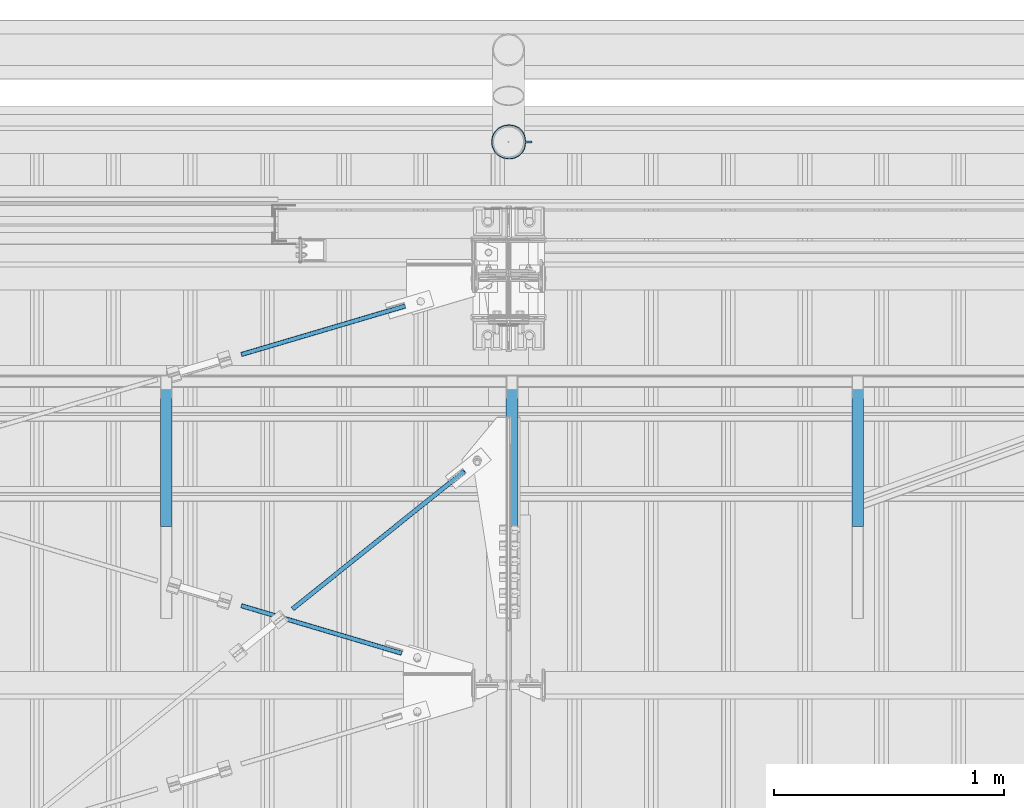
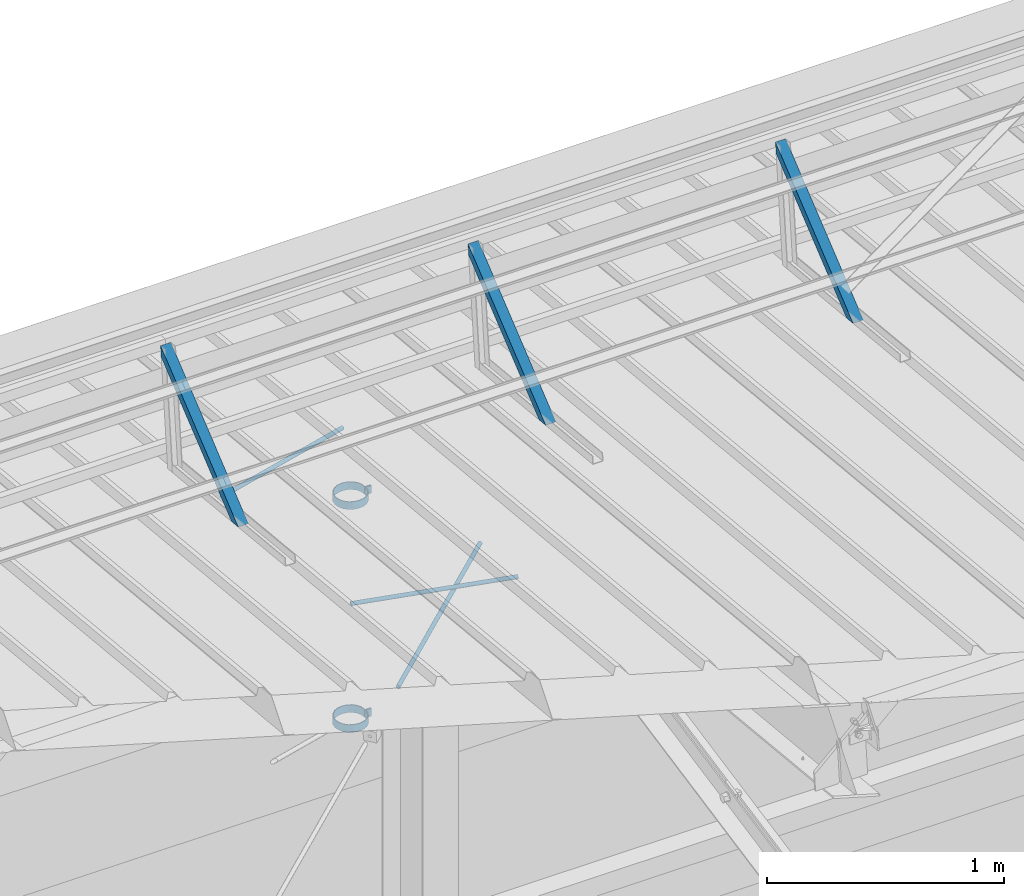
# One storey, part 305 of 709: 5 beams, 3 members, 3 openings, 8 elements without a shape of their own.
"""IFC4 building model written with IfcOpenShell, lengths in millimetres."""

from ifc_helpers import new_model, si_unit, direction, frame, origin_with_axes, place, context, subcontext, project, spatial, line, indexed_curve, outline, extrude, polygons, material, element, aggregate, save


model = new_model("IFC4")

# Units and contexts
model_context = context("Model", 3, precision=0.2, world=origin_with_axes(), true_north=direction((0.0, 1.0)))
body_context = subcontext(model_context, "Body", "Model", "MODEL_VIEW")
reference_context = subcontext(model_context, "Reference", "Model", "MODEL_VIEW")
ifc_project = project(units=[si_unit("LENGTHUNIT", "METRE", prefix="MILLI"), si_unit("AREAUNIT", "SQUARE_METRE"), si_unit("VOLUMEUNIT", "CUBIC_METRE"), si_unit("MASSUNIT", "GRAM", prefix="KILO"), si_unit("TIMEUNIT", "SECOND"), si_unit("PLANEANGLEUNIT", "RADIAN"), si_unit("SOLIDANGLEUNIT", "STERADIAN"), si_unit("THERMODYNAMICTEMPERATUREUNIT", "DEGREE_CELSIUS"), si_unit("LUMINOUSINTENSITYUNIT", "LUMEN")], contexts=[model_context])

# Site, building, storey
site_placement = place(None, origin_with_axes())
site = spatial("IfcSite", under=ifc_project, at=site_placement, CompositionType="ELEMENT")
building_placement = place(site_placement, origin_with_axes())
building = spatial("IfcBuilding", under=site, at=building_placement, Name="Undefined", CompositionType="ELEMENT")
storey_placement = place(building_placement, origin_with_axes())
storey = spatial("IfcBuildingStorey", under=building, at=storey_placement, Name="Undefined", CompositionType="ELEMENT", Elevation=0.0)

# Assembly, beam, voiding feature
assembly_1_placement = place(storey_placement, frame((8916.07962, 20275.59044, 6772.92001), z_axis=(0.625451877, -0.7802627439, 1e-10), x_axis=(0.7742288439, 0.6206151549, 0.124123031)))
assembly_1 = element("IfcElementAssembly", 1, at=assembly_1_placement, inside=storey)
ifc_material_1 = material(Name="C355-5", Category="STEEL")
beam_1_placement = place(assembly_1_placement, origin_with_axes())
beam_1 = element("IfcBeam", 2, at=beam_1_placement, material=ifc_material_1, ObjectType="481", context=body_context, shape_type="Tessellation", body=[
    polygons([(1153.34134, -5.0, 8.66025), (1153.34134, -7.07107, 7.07107), (1153.34134, -8.66025, 5.0), (1153.34134, -9.65926, 2.58819), (1153.34134, -10.0, 0.0), (1153.34134, -9.65926, -2.58819), (1153.34134, -8.66025, -5.0), (1153.34134, -7.07107, -7.07107), (1153.34134, -5.0, -8.66025), (1153.34134, -2.58819, -9.65926), (1153.34134, 0.0, -10.0), (1153.34134, 2.58819, -9.65926), (1153.34134, 5.0, -8.66025), (1153.34134, 7.07107, -7.07107), (1153.34134, 8.66025, -5.0), (1153.34134, 9.65926, -2.58819), (1153.34134, 10.0, 0.0), (1153.34134, 9.65926, 2.58819), (1153.34134, 8.66025, 5.0), (1153.34134, 7.07107, 7.07107), (1153.34134, 5.0, 8.66025), (1153.34134, 2.58819, 9.65926), (1153.34134, 0.0, 10.0), (1153.34134, -2.58819, 9.65926), (190.0, 10.0, 0.0), (190.0, 9.65926, 2.58819), (190.0, 8.66025, 5.0), (190.0, 7.07107, 7.07107), (190.0, 5.0, 8.66025), (190.0, 2.58819, 9.65926), (190.0, 0.0, 10.0), (190.0, -2.58819, 9.65926), (190.0, -5.0, 8.66025), (190.0, -7.07107, 7.07107), (190.0, -8.66025, 5.0), (190.0, -9.65926, 2.58819), (190.0, -10.0, 0.0), (190.0, -9.65926, -2.58819), (190.0, -8.66025, -5.0), (190.0, -7.07107, -7.07107), (190.0, -5.0, -8.66025), (190.0, -2.58819, -9.65926), (190.0, 0.0, -10.0), (190.0, 2.58819, -9.65926), (190.0, 5.0, -8.66025), (190.0, 7.07107, -7.07107), (190.0, 8.66025, -5.0), (190.0, 9.65926, -2.58819), (10.0, 7.36122, 4.25), (190.0, 7.36122, 4.25), (190.0, 8.21037, 2.19996), (10.0, 8.21037, 2.19996), (10.0, 6.01041, 6.01041), (190.0, 6.01041, 6.01041), (10.0, 4.25, 7.36122), (190.0, 4.25, 7.36122), (10.0, 2.19996, 8.21037), (190.0, 2.19996, 8.21037), (10.0, 0.0, 8.5), (190.0, 0.0, 8.5), (10.0, -2.19996, 8.21037), (190.0, -2.19996, 8.21037), (10.0, -4.25, 7.36122), (190.0, -4.25, 7.36122), (10.0, -6.01041, 6.01041), (190.0, -6.01041, 6.01041), (10.0, -7.36122, 4.25), (190.0, -7.36122, 4.25), (10.0, -8.21037, 2.19996), (190.0, -8.21037, 2.19996), (10.0, -8.5, 0.0), (190.0, -8.5, 0.0), (10.0, -8.21037, -2.19996), (190.0, -8.21037, -2.19996), (10.0, -7.36122, -4.25), (190.0, -7.36122, -4.25), (10.0, -6.01041, -6.01041), (190.0, -6.01041, -6.01041), (10.0, -4.25, -7.36122), (190.0, -4.25, -7.36122), (10.0, -2.19996, -8.21037), (190.0, -2.19996, -8.21037), (10.0, 0.0, -8.5), (190.0, 0.0, -8.5), (10.0, 2.19996, -8.21037), (190.0, 2.19996, -8.21037), (10.0, 4.25, -7.36122), (190.0, 4.25, -7.36122), (10.0, 6.01041, -6.01041), (190.0, 6.01041, -6.01041), (10.0, 7.36122, -4.25), (190.0, 7.36122, -4.25), (10.0, 8.21037, -2.19996), (190.0, 8.21037, -2.19996), (10.0, 8.5, 0.0), (190.0, 8.5, 0.0)], [[[1, 2, 3, 4, 5, 6, 7, 8, 9, 10, 11, 12, 13, 14, 15, 16, 17, 18, 19, 20, 21, 22, 23, 24]], [[18, 17, 25, 26]], [[19, 18, 26, 27]], [[20, 19, 27, 28]], [[21, 20, 28, 29]], [[22, 21, 29, 30]], [[23, 22, 30, 31]], [[24, 23, 31, 32]], [[1, 24, 32, 33]], [[2, 1, 33, 34]], [[3, 2, 34, 35]], [[4, 3, 35, 36]], [[5, 4, 36, 37]], [[6, 5, 37, 38]], [[7, 6, 38, 39]], [[8, 7, 39, 40]], [[9, 8, 40, 41]], [[10, 9, 41, 42]], [[11, 10, 42, 43]], [[12, 11, 43, 44]], [[13, 12, 44, 45]], [[14, 13, 45, 46]], [[15, 14, 46, 47]], [[16, 15, 47, 48]], [[17, 16, 48, 25]], [[25, 48, 47, 46, 45, 44, 43, 42, 41, 40, 39, 38, 37, 36, 35, 34, 33, 32, 31, 30, 29, 28, 27, 26], [74, 76, 78, 80, 82, 84, 86, 88, 90, 92, 94, 96, 51, 50, 54, 56, 58, 60, 62, 64, 66, 68, 70, 72]], [[49, 50, 51, 52]], [[53, 54, 50, 49]], [[55, 56, 54, 53]], [[57, 58, 56, 55]], [[59, 60, 58, 57]], [[61, 62, 60, 59]], [[63, 64, 62, 61]], [[65, 66, 64, 63]], [[67, 68, 66, 65]], [[69, 70, 68, 67]], [[71, 72, 70, 69]], [[73, 74, 72, 71]], [[75, 76, 74, 73]], [[77, 78, 76, 75]], [[79, 80, 78, 77]], [[81, 82, 80, 79]], [[83, 84, 82, 81]], [[85, 86, 84, 83]], [[87, 88, 86, 85]], [[89, 90, 88, 87]], [[91, 92, 90, 89]], [[93, 94, 92, 91]], [[95, 96, 94, 93]], [[52, 51, 96, 95]], [[91, 89, 87, 85, 83, 81, 79, 77, 75, 73, 71, 69, 67, 65, 63, 61, 59, 57, 55, 53, 49, 52, 95, 93]]], closed=True),
])
voiding_feature_1_placement = place(beam_1_placement, frame((10.0, 0.0, 0.0), z_axis=(0.0, -1.0, 0.0), x_axis=(1.0, 0.0, 0.0)))
element("IfcVoidingFeature", 3, at=voiding_feature_1_placement, cuts=beam_1, PredefinedType="HOLE", context=reference_context, identifier="Reference", shape_type="SolidModel", body=[
    extrude(outline(indexed_curve([(10.5, 0.0), (10.14222, 2.7176), (9.09327, 5.25), (7.42462, 7.42462), (5.25, 9.09327), (2.7176, 10.14222), (0.0, 10.5), (-2.7176, 10.14222), (-5.25, 9.09327), (-7.42462, 7.42462), (-9.09327, 5.25), (-10.14222, 2.7176), (-10.5, 0.0), (-10.14222, -2.7176), (-9.09327, -5.25), (-7.42462, -7.42462), (-5.25, -9.09327), (-2.7176, -10.14222), (0.0, -10.5), (2.7176, -10.14222), (5.25, -9.09327), (7.42462, -7.42462), (9.09327, -5.25), (10.14222, -2.7176)], segments=[line(1, 2, 3, 4, 5, 6, 7, 8, 9, 10, 11, 12, 13, 14, 15, 16, 17, 18, 19, 20, 21, 22, 23, 24, 1)])), frame((0.0, 0.0, 0.0), z_axis=(-1.0, 0.0, 0.0), x_axis=(0.0, 0.0, 1.0)), (0.0, 0.0, -1.0), 180.0),
])
aggregate(assembly_1, [beam_1])

assembly_2_placement = place(storey_placement, frame((8658.15773, 21443.50385, 7192.15363), z_axis=(0.2852311229, -0.9537021177, 0.0953702118), x_axis=(0.9584587662, 0.2838155751, -0.028381558)))
assembly_2 = element("IfcElementAssembly", 4, at=assembly_2_placement, inside=storey)
beam_2_placement = place(assembly_2_placement, origin_with_axes())
beam_2 = element("IfcBeam", 5, at=beam_2_placement, material=ifc_material_1, ObjectType="571", context=body_context, shape_type="Tessellation", body=[
    polygons([(931.9749, -5.0, 8.66025), (931.9749, -7.07107, 7.07107), (931.9749, -8.66025, 5.0), (931.9749, -9.65926, 2.58819), (931.9749, -10.0, 0.0), (931.9749, -9.65926, -2.58819), (931.9749, -8.66025, -5.0), (931.9749, -7.07107, -7.07107), (931.9749, -5.0, -8.66025), (931.9749, -2.58819, -9.65926), (931.9749, 0.0, -10.0), (931.9749, 2.58819, -9.65926), (931.9749, 5.0, -8.66025), (931.9749, 7.07107, -7.07107), (931.9749, 8.66025, -5.0), (931.9749, 9.65926, -2.58819), (931.9749, 10.0, 0.0), (931.9749, 9.65926, 2.58819), (931.9749, 8.66025, 5.0), (931.9749, 7.07107, 7.07107), (931.9749, 5.0, 8.66025), (931.9749, 2.58819, 9.65926), (931.9749, 0.0, 10.0), (931.9749, -2.58819, 9.65926), (190.0, 10.0, 0.0), (190.0, 9.65926, 2.58819), (190.0, 8.66025, 5.0), (190.0, 7.07107, 7.07107), (190.0, 5.0, 8.66025), (190.0, 2.58819, 9.65926), (190.0, 0.0, 10.0), (190.0, -2.58819, 9.65926), (190.0, -5.0, 8.66025), (190.0, -7.07107, 7.07107), (190.0, -8.66025, 5.0), (190.0, -9.65926, 2.58819), (190.0, -10.0, 0.0), (190.0, -9.65926, -2.58819), (190.0, -8.66025, -5.0), (190.0, -7.07107, -7.07107), (190.0, -5.0, -8.66025), (190.0, -2.58819, -9.65926), (190.0, 0.0, -10.0), (190.0, 2.58819, -9.65926), (190.0, 5.0, -8.66025), (190.0, 7.07107, -7.07107), (190.0, 8.66025, -5.0), (190.0, 9.65926, -2.58819), (10.0, 7.36122, 4.25), (190.0, 7.36122, 4.25), (190.0, 8.21037, 2.19996), (10.0, 8.21037, 2.19996), (10.0, 6.01041, 6.01041), (190.0, 6.01041, 6.01041), (10.0, 4.25, 7.36122), (190.0, 4.25, 7.36122), (10.0, 2.19996, 8.21037), (190.0, 2.19996, 8.21037), (10.0, 0.0, 8.5), (190.0, 0.0, 8.5), (10.0, -2.19996, 8.21037), (190.0, -2.19996, 8.21037), (10.0, -4.25, 7.36122), (190.0, -4.25, 7.36122), (10.0, -6.01041, 6.01041), (190.0, -6.01041, 6.01041), (10.0, -7.36122, 4.25), (190.0, -7.36122, 4.25), (10.0, -8.21037, 2.19996), (190.0, -8.21037, 2.19996), (10.0, -8.5, 0.0), (190.0, -8.5, 0.0), (10.0, -8.21037, -2.19996), (190.0, -8.21037, -2.19996), (10.0, -7.36122, -4.25), (190.0, -7.36122, -4.25), (10.0, -6.01041, -6.01041), (190.0, -6.01041, -6.01041), (10.0, -4.25, -7.36122), (190.0, -4.25, -7.36122), (10.0, -2.19996, -8.21037), (190.0, -2.19996, -8.21037), (10.0, 0.0, -8.5), (190.0, 0.0, -8.5), (10.0, 2.19996, -8.21037), (190.0, 2.19996, -8.21037), (10.0, 4.25, -7.36122), (190.0, 4.25, -7.36122), (10.0, 6.01041, -6.01041), (190.0, 6.01041, -6.01041), (10.0, 7.36122, -4.25), (190.0, 7.36122, -4.25), (10.0, 8.21037, -2.19996), (190.0, 8.21037, -2.19996), (10.0, 8.5, 0.0), (190.0, 8.5, 0.0)], [[[1, 2, 3, 4, 5, 6, 7, 8, 9, 10, 11, 12, 13, 14, 15, 16, 17, 18, 19, 20, 21, 22, 23, 24]], [[18, 17, 25, 26]], [[19, 18, 26, 27]], [[20, 19, 27, 28]], [[21, 20, 28, 29]], [[22, 21, 29, 30]], [[23, 22, 30, 31]], [[24, 23, 31, 32]], [[1, 24, 32, 33]], [[2, 1, 33, 34]], [[3, 2, 34, 35]], [[4, 3, 35, 36]], [[5, 4, 36, 37]], [[6, 5, 37, 38]], [[7, 6, 38, 39]], [[8, 7, 39, 40]], [[9, 8, 40, 41]], [[10, 9, 41, 42]], [[11, 10, 42, 43]], [[12, 11, 43, 44]], [[13, 12, 44, 45]], [[14, 13, 45, 46]], [[15, 14, 46, 47]], [[16, 15, 47, 48]], [[17, 16, 48, 25]], [[25, 48, 47, 46, 45, 44, 43, 42, 41, 40, 39, 38, 37, 36, 35, 34, 33, 32, 31, 30, 29, 28, 27, 26], [74, 76, 78, 80, 82, 84, 86, 88, 90, 92, 94, 96, 51, 50, 54, 56, 58, 60, 62, 64, 66, 68, 70, 72]], [[49, 50, 51, 52]], [[53, 54, 50, 49]], [[55, 56, 54, 53]], [[57, 58, 56, 55]], [[59, 60, 58, 57]], [[61, 62, 60, 59]], [[63, 64, 62, 61]], [[65, 66, 64, 63]], [[67, 68, 66, 65]], [[69, 70, 68, 67]], [[71, 72, 70, 69]], [[73, 74, 72, 71]], [[75, 76, 74, 73]], [[77, 78, 76, 75]], [[79, 80, 78, 77]], [[81, 82, 80, 79]], [[83, 84, 82, 81]], [[85, 86, 84, 83]], [[87, 88, 86, 85]], [[89, 90, 88, 87]], [[91, 92, 90, 89]], [[93, 94, 92, 91]], [[95, 96, 94, 93]], [[52, 51, 96, 95]], [[91, 89, 87, 85, 83, 81, 79, 77, 75, 73, 71, 69, 67, 65, 63, 61, 59, 57, 55, 53, 49, 52, 95, 93]]], closed=True),
])
voiding_feature_2_placement = place(beam_2_placement, frame((10.0, 0.0, 0.0), z_axis=(0.0, -1.0, 0.0), x_axis=(1.0, 0.0, 0.0)))
element("IfcVoidingFeature", 6, at=voiding_feature_2_placement, cuts=beam_2, PredefinedType="HOLE", context=reference_context, identifier="Reference", shape_type="SolidModel", body=[
    extrude(outline(indexed_curve([(10.5, 0.0), (10.14222, 2.7176), (9.09327, 5.25), (7.42462, 7.42462), (5.25, 9.09327), (2.7176, 10.14222), (0.0, 10.5), (-2.7176, 10.14222), (-5.25, 9.09327), (-7.42462, 7.42462), (-9.09327, 5.25), (-10.14222, 2.7176), (-10.5, 0.0), (-10.14222, -2.7176), (-9.09327, -5.25), (-7.42462, -7.42462), (-5.25, -9.09327), (-2.7176, -10.14222), (0.0, -10.5), (2.7176, -10.14222), (5.25, -9.09327), (7.42462, -7.42462), (9.09327, -5.25), (10.14222, -2.7176)], segments=[line(1, 2, 3, 4, 5, 6, 7, 8, 9, 10, 11, 12, 13, 14, 15, 16, 17, 18, 19, 20, 21, 22, 23, 24, 1)])), frame((0.0, 0.0, 0.0), z_axis=(-1.0, 0.0, 0.0), x_axis=(0.0, 0.0, 1.0)), (0.0, 0.0, -1.0), 180.0),
])
aggregate(assembly_2, [beam_2])

assembly_3_placement = place(storey_placement, frame((8658.15773, 20461.48771, 7290.35524), z_axis=(-0.2852311229, -0.9537021177, 0.0953702118), x_axis=(0.9584587662, -0.2838155751, 0.028381558)))
assembly_3 = element("IfcElementAssembly", 7, at=assembly_3_placement, inside=storey)
beam_3_placement = place(assembly_3_placement, origin_with_axes())
beam_3 = element("IfcBeam", 8, at=beam_3_placement, material=ifc_material_1, ObjectType="569", context=body_context, shape_type="Tessellation", body=[
    polygons([(916.9749, -5.0, 8.66025), (916.9749, -7.07107, 7.07107), (916.9749, -8.66025, 5.0), (916.9749, -9.65926, 2.58819), (916.9749, -10.0, 0.0), (916.9749, -9.65926, -2.58819), (916.9749, -8.66025, -5.0), (916.9749, -7.07107, -7.07107), (916.9749, -5.0, -8.66025), (916.9749, -2.58819, -9.65926), (916.9749, 0.0, -10.0), (916.9749, 2.58819, -9.65926), (916.9749, 5.0, -8.66025), (916.9749, 7.07107, -7.07107), (916.9749, 8.66025, -5.0), (916.9749, 9.65926, -2.58819), (916.9749, 10.0, 0.0), (916.9749, 9.65926, 2.58819), (916.9749, 8.66025, 5.0), (916.9749, 7.07107, 7.07107), (916.9749, 5.0, 8.66025), (916.9749, 2.58819, 9.65926), (916.9749, 0.0, 10.0), (916.9749, -2.58819, 9.65926), (190.0, 10.0, 0.0), (190.0, 9.65926, 2.58819), (190.0, 8.66025, 5.0), (190.0, 7.07107, 7.07107), (190.0, 5.0, 8.66025), (190.0, 2.58819, 9.65926), (190.0, 0.0, 10.0), (190.0, -2.58819, 9.65926), (190.0, -5.0, 8.66025), (190.0, -7.07107, 7.07107), (190.0, -8.66025, 5.0), (190.0, -9.65926, 2.58819), (190.0, -10.0, 0.0), (190.0, -9.65926, -2.58819), (190.0, -8.66025, -5.0), (190.0, -7.07107, -7.07107), (190.0, -5.0, -8.66025), (190.0, -2.58819, -9.65926), (190.0, 0.0, -10.0), (190.0, 2.58819, -9.65926), (190.0, 5.0, -8.66025), (190.0, 7.07107, -7.07107), (190.0, 8.66025, -5.0), (190.0, 9.65926, -2.58819), (10.0, 7.36122, 4.25), (190.0, 7.36122, 4.25), (190.0, 8.21037, 2.19996), (10.0, 8.21037, 2.19996), (10.0, 6.01041, 6.01041), (190.0, 6.01041, 6.01041), (10.0, 4.25, 7.36122), (190.0, 4.25, 7.36122), (10.0, 2.19996, 8.21037), (190.0, 2.19996, 8.21037), (10.0, 0.0, 8.5), (190.0, 0.0, 8.5), (10.0, -2.19996, 8.21037), (190.0, -2.19996, 8.21037), (10.0, -4.25, 7.36122), (190.0, -4.25, 7.36122), (10.0, -6.01041, 6.01041), (190.0, -6.01041, 6.01041), (10.0, -7.36122, 4.25), (190.0, -7.36122, 4.25), (10.0, -8.21037, 2.19996), (190.0, -8.21037, 2.19996), (10.0, -8.5, 0.0), (190.0, -8.5, 0.0), (10.0, -8.21037, -2.19996), (190.0, -8.21037, -2.19996), (10.0, -7.36122, -4.25), (190.0, -7.36122, -4.25), (10.0, -6.01041, -6.01041), (190.0, -6.01041, -6.01041), (10.0, -4.25, -7.36122), (190.0, -4.25, -7.36122), (10.0, -2.19996, -8.21037), (190.0, -2.19996, -8.21037), (10.0, 0.0, -8.5), (190.0, 0.0, -8.5), (10.0, 2.19996, -8.21037), (190.0, 2.19996, -8.21037), (10.0, 4.25, -7.36122), (190.0, 4.25, -7.36122), (10.0, 6.01041, -6.01041), (190.0, 6.01041, -6.01041), (10.0, 7.36122, -4.25), (190.0, 7.36122, -4.25), (10.0, 8.21037, -2.19996), (190.0, 8.21037, -2.19996), (10.0, 8.5, 0.0), (190.0, 8.5, 0.0)], [[[1, 2, 3, 4, 5, 6, 7, 8, 9, 10, 11, 12, 13, 14, 15, 16, 17, 18, 19, 20, 21, 22, 23, 24]], [[18, 17, 25, 26]], [[19, 18, 26, 27]], [[20, 19, 27, 28]], [[21, 20, 28, 29]], [[22, 21, 29, 30]], [[23, 22, 30, 31]], [[24, 23, 31, 32]], [[1, 24, 32, 33]], [[2, 1, 33, 34]], [[3, 2, 34, 35]], [[4, 3, 35, 36]], [[5, 4, 36, 37]], [[6, 5, 37, 38]], [[7, 6, 38, 39]], [[8, 7, 39, 40]], [[9, 8, 40, 41]], [[10, 9, 41, 42]], [[11, 10, 42, 43]], [[12, 11, 43, 44]], [[13, 12, 44, 45]], [[14, 13, 45, 46]], [[15, 14, 46, 47]], [[16, 15, 47, 48]], [[17, 16, 48, 25]], [[25, 48, 47, 46, 45, 44, 43, 42, 41, 40, 39, 38, 37, 36, 35, 34, 33, 32, 31, 30, 29, 28, 27, 26], [74, 76, 78, 80, 82, 84, 86, 88, 90, 92, 94, 96, 51, 50, 54, 56, 58, 60, 62, 64, 66, 68, 70, 72]], [[49, 50, 51, 52]], [[53, 54, 50, 49]], [[55, 56, 54, 53]], [[57, 58, 56, 55]], [[59, 60, 58, 57]], [[61, 62, 60, 59]], [[63, 64, 62, 61]], [[65, 66, 64, 63]], [[67, 68, 66, 65]], [[69, 70, 68, 67]], [[71, 72, 70, 69]], [[73, 74, 72, 71]], [[75, 76, 74, 73]], [[77, 78, 76, 75]], [[79, 80, 78, 77]], [[81, 82, 80, 79]], [[83, 84, 82, 81]], [[85, 86, 84, 83]], [[87, 88, 86, 85]], [[89, 90, 88, 87]], [[91, 92, 90, 89]], [[93, 94, 92, 91]], [[95, 96, 94, 93]], [[52, 51, 96, 95]], [[91, 89, 87, 85, 83, 81, 79, 77, 75, 73, 71, 69, 67, 65, 63, 61, 59, 57, 55, 53, 49, 52, 95, 93]]], closed=True),
])
voiding_feature_3_placement = place(beam_3_placement, frame((10.0, 0.0, 0.0), z_axis=(0.0, -1.0, 0.0), x_axis=(1.0, 0.0, 0.0)))
element("IfcVoidingFeature", 9, at=voiding_feature_3_placement, cuts=beam_3, PredefinedType="HOLE", context=reference_context, identifier="Reference", shape_type="SolidModel", body=[
    extrude(outline(indexed_curve([(10.5, 0.0), (10.14222, 2.7176), (9.09327, 5.25), (7.42462, 7.42462), (5.25, 9.09327), (2.7176, 10.14222), (0.0, 10.5), (-2.7176, 10.14222), (-5.25, 9.09327), (-7.42462, 7.42462), (-9.09327, 5.25), (-10.14222, 2.7176), (-10.5, 0.0), (-10.14222, -2.7176), (-9.09327, -5.25), (-7.42462, -7.42462), (-5.25, -9.09327), (-2.7176, -10.14222), (0.0, -10.5), (2.7176, -10.14222), (5.25, -9.09327), (7.42462, -7.42462), (9.09327, -5.25), (10.14222, -2.7176)], segments=[line(1, 2, 3, 4, 5, 6, 7, 8, 9, 10, 11, 12, 13, 14, 15, 16, 17, 18, 19, 20, 21, 22, 23, 24, 1)])), frame((0.0, 0.0, 0.0), z_axis=(-1.0, 0.0, 0.0), x_axis=(0.0, 0.0, 1.0)), (0.0, 0.0, -1.0), 180.0),
])
aggregate(assembly_3, [beam_3])

# Assembly, member
assembly_4_placement = place(storey_placement, frame((11515.0, 20762.95162, 7589.66203), z_axis=(0.0, 0.6332377902, -0.7739572992), x_axis=(0.0, 0.7739572992, 0.6332377902)))
assembly_4 = element("IfcElementAssembly", 10, at=assembly_4_placement, inside=storey)
ifc_material_2 = material(Name="Steel_Undefined", Category="STEEL")
member_1_placement = place(assembly_4_placement, origin_with_axes())
member_1 = element("IfcMember", 11, at=member_1_placement, material=ifc_material_2, ObjectType="603", context=body_context, shape_type="Tessellation", body=[
    polygons([(0.0, -25.0, -20.0), (0.0, 25.0, -20.0), (848.52814, 25.0, -20.0), (848.52814, -25.0, -20.0), (40.0, 25.0, 20.0), (808.52814, 25.0, 20.0), (40.0, 22.5, 20.0), (808.52814, 22.5, 20.0), (2.5, 22.5, -17.5), (846.02814, 22.5, -17.5), (2.5, -22.5, -17.5), (846.02814, -22.5, -17.5), (40.0, -22.5, 20.0), (808.52814, -22.5, 20.0), (40.0, -25.0, 20.0), (808.52814, -25.0, 20.0)], [[[1, 2, 3, 4]], [[2, 5, 6, 3]], [[5, 7, 8, 6]], [[7, 9, 10, 8]], [[9, 11, 12, 10]], [[11, 13, 14, 12]], [[13, 15, 16, 14]], [[15, 1, 4, 16]], [[6, 8, 10, 12, 14, 16, 4, 3]], [[15, 13, 11, 9, 7, 5, 2, 1]]], closed=True),
])
aggregate(assembly_4, [member_1])

assembly_5_placement = place(storey_placement, frame((10015.0, 20762.95162, 7589.66203), z_axis=(0.0, 0.6332377902, -0.7739572992), x_axis=(0.0, 0.7739572992, 0.6332377902)))
assembly_5 = element("IfcElementAssembly", 12, at=assembly_5_placement, inside=storey)
member_2_placement = place(assembly_5_placement, origin_with_axes())
member_2 = element("IfcMember", 13, at=member_2_placement, material=ifc_material_2, ObjectType="603", context=body_context, shape_type="Tessellation", body=[
    polygons([(0.0, -25.0, -20.0), (0.0, 25.0, -20.0), (848.52814, 25.0, -20.0), (848.52814, -25.0, -20.0), (40.0, 25.0, 20.0), (808.52814, 25.0, 20.0), (40.0, 22.5, 20.0), (808.52814, 22.5, 20.0), (2.5, 22.5, -17.5), (846.02814, 22.5, -17.5), (2.5, -22.5, -17.5), (846.02814, -22.5, -17.5), (40.0, -22.5, 20.0), (808.52814, -22.5, 20.0), (40.0, -25.0, 20.0), (808.52814, -25.0, 20.0)], [[[1, 2, 3, 4]], [[2, 5, 6, 3]], [[5, 7, 8, 6]], [[7, 9, 10, 8]], [[9, 11, 12, 10]], [[11, 13, 14, 12]], [[13, 15, 16, 14]], [[15, 1, 4, 16]], [[6, 8, 10, 12, 14, 16, 4, 3]], [[15, 13, 11, 9, 7, 5, 2, 1]]], closed=True),
])
aggregate(assembly_5, [member_2])

assembly_6_placement = place(storey_placement, frame((8515.0, 20762.95162, 7589.66203), z_axis=(0.0, 0.6332377902, -0.7739572992), x_axis=(0.0, 0.7739572992, 0.6332377902)))
assembly_6 = element("IfcElementAssembly", 14, at=assembly_6_placement, inside=storey)
member_3_placement = place(assembly_6_placement, origin_with_axes())
member_3 = element("IfcMember", 15, at=member_3_placement, material=ifc_material_2, ObjectType="603", context=body_context, shape_type="Tessellation", body=[
    polygons([(0.0, -25.0, -20.0), (0.0, 25.0, -20.0), (848.52814, 25.0, -20.0), (848.52814, -25.0, -20.0), (40.0, 25.0, 20.0), (808.52814, 25.0, 20.0), (40.0, 22.5, 20.0), (808.52814, 22.5, 20.0), (2.5, 22.5, -17.5), (846.02814, 22.5, -17.5), (2.5, -22.5, -17.5), (846.02814, -22.5, -17.5), (40.0, -22.5, 20.0), (808.52814, -22.5, 20.0), (40.0, -25.0, 20.0), (808.52814, -25.0, 20.0)], [[[1, 2, 3, 4]], [[2, 5, 6, 3]], [[5, 7, 8, 6]], [[7, 9, 10, 8]], [[9, 11, 12, 10]], [[11, 13, 14, 12]], [[13, 15, 16, 14]], [[15, 1, 4, 16]], [[6, 8, 10, 12, 14, 16, 4, 3]], [[15, 13, 11, 9, 7, 5, 2, 1]]], closed=True),
])
aggregate(assembly_6, [member_3])

# Assembly, beam
assembly_7_placement = place(storey_placement, frame((10101.0, 22422.5, 6226.92297), z_axis=(0.0, 1.0, 0.0), x_axis=(-1.0, 0.0, 0.0)))
assembly_7 = element("IfcElementAssembly", 16, at=assembly_7_placement, inside=storey)
beam_4_placement = place(assembly_7_placement, origin_with_axes())
beam_4 = element("IfcBeam", 17, at=beam_4_placement, material=ifc_material_2, ObjectType="616", context=body_context, shape_type="Tessellation", body=[
    polygons([(0.0, -20.0, 2.0), (0.0, 20.0, 2.0), (0.0, 20.0, -2.0), (0.0, -20.0, -2.0), (30.0, 20.0, -2.0), (30.0, -20.0, -2.0), (26.0, -20.0, 2.0), (26.0, 20.0, 2.0), (30.0, 20.0, 3.5), (30.0, -20.0, 3.5), (26.0, -20.0, 3.5), (26.0, 20.0, 3.5), (33.18133, 20.0, 23.5861), (33.18133, -20.0, 23.5861), (29.3771, -20.0, 24.82217), (29.3771, 20.0, 24.82217), (39.17783, -20.0, 44.05718), (39.17783, 20.0, 44.05718), (42.4139, 20.0, 41.70604), (42.4139, -20.0, 41.70604), (54.44282, -20.0, 59.32217), (54.44282, 20.0, 59.32217), (56.79396, 20.0, 56.0861), (56.79396, -20.0, 56.0861), (73.67783, -20.0, 69.1229), (73.67783, 20.0, 69.1229), (74.9139, 20.0, 65.31867), (74.9139, -20.0, 65.31867), (95.0, -20.0, 72.5), (95.0, 20.0, 72.5), (95.0, 20.0, 68.5), (95.0, -20.0, 68.5), (102.0, 20.0, 68.5), (102.0, -20.0, 68.5), (102.0, -20.0, 72.5), (102.0, 20.0, 72.5), (123.63119, 20.0, 65.07396), (123.63119, -20.0, 65.07396), (124.86726, -20.0, 68.87818), (124.86726, 20.0, 68.87818), (145.49611, -20.0, 58.36726), (145.49611, 20.0, 58.36726), (143.14497, 20.0, 55.13119), (143.14497, -20.0, 55.13119), (161.86726, -20.0, 41.99611), (161.86726, 20.0, 41.99611), (158.63119, 20.0, 39.64497), (158.63119, -20.0, 39.64497), (172.37818, -20.0, 21.36726), (172.37818, 20.0, 21.36726), (168.57396, 20.0, 20.13119), (168.57396, -20.0, 20.13119), (176.0, -20.0, -1.5), (176.0, 20.0, -1.5), (172.0, 20.0, -1.5), (172.0, -20.0, -1.5), (172.0, 20.0, -3.5), (172.0, -20.0, -3.5), (176.0, -20.0, -3.5), (176.0, 20.0, -3.5), (168.57396, 20.0, -25.13119), (168.57396, -20.0, -25.13119), (172.37818, -20.0, -26.36726), (172.37818, 20.0, -26.36726), (161.86726, -20.0, -46.99611), (161.86726, 20.0, -46.99611), (158.63119, 20.0, -44.64497), (158.63119, -20.0, -44.64497), (145.49611, -20.0, -63.36726), (145.49611, 20.0, -63.36726), (143.14497, 20.0, -60.13119), (143.14497, -20.0, -60.13119), (124.86726, -20.0, -73.87818), (124.86726, 20.0, -73.87818), (123.63119, 20.0, -70.07396), (123.63119, -20.0, -70.07396), (102.0, -20.0, -77.5), (102.0, 20.0, -77.5), (102.0, 20.0, -73.5), (102.0, -20.0, -73.5), (95.0, 20.0, -73.5), (95.0, -20.0, -73.5), (95.0, -20.0, -77.5), (95.0, 20.0, -77.5), (74.9139, 20.0, -70.31867), (74.9139, -20.0, -70.31867), (73.67783, -20.0, -74.1229), (73.67783, 20.0, -74.1229), (54.44282, -20.0, -64.32217), (54.44282, 20.0, -64.32217), (56.79396, 20.0, -61.0861), (56.79396, -20.0, -61.0861), (39.17783, -20.0, -49.05718), (39.17783, 20.0, -49.05718), (42.4139, 20.0, -46.70604), (42.4139, -20.0, -46.70604), (29.3771, -20.0, -29.82217), (29.3771, 20.0, -29.82217), (33.18133, 20.0, -28.5861), (33.18133, -20.0, -28.5861), (26.0, -20.0, -8.5), (26.0, 20.0, -8.5), (30.0, 20.0, -8.5), (30.0, -20.0, -8.5), (30.0, 20.0, -3.0), (30.0, -20.0, -3.0), (26.0, -20.0, -7.0), (26.0, 20.0, -7.0), (0.0, 20.0, -3.0), (0.0, -20.0, -3.0), (0.0, 20.0, -7.0), (0.0, -20.0, -7.0)], [[[1, 2, 3, 4]], [[4, 3, 5, 6]], [[2, 1, 7, 8]], [[6, 5, 9, 10]], [[8, 7, 11, 12]], [[10, 9, 13, 14]], [[12, 11, 15, 16]], [[15, 17, 18, 16]], [[13, 19, 20, 14]], [[17, 21, 22, 18]], [[19, 23, 24, 20]], [[21, 25, 26, 22]], [[23, 27, 28, 24]], [[25, 29, 30, 26]], [[27, 31, 32, 28]], [[32, 31, 33, 34]], [[30, 29, 35, 36]], [[34, 33, 37, 38]], [[36, 35, 39, 40]], [[39, 41, 42, 40]], [[37, 43, 44, 38]], [[41, 45, 46, 42]], [[43, 47, 48, 44]], [[45, 49, 50, 46]], [[47, 51, 52, 48]], [[49, 53, 54, 50]], [[51, 55, 56, 52]], [[56, 55, 57, 58]], [[54, 53, 59, 60]], [[58, 57, 61, 62]], [[60, 59, 63, 64]], [[63, 65, 66, 64]], [[61, 67, 68, 62]], [[65, 69, 70, 66]], [[67, 71, 72, 68]], [[69, 73, 74, 70]], [[71, 75, 76, 72]], [[73, 77, 78, 74]], [[75, 79, 80, 76]], [[80, 79, 81, 82]], [[78, 77, 83, 84]], [[82, 81, 85, 86]], [[84, 83, 87, 88]], [[87, 89, 90, 88]], [[85, 91, 92, 86]], [[89, 93, 94, 90]], [[91, 95, 96, 92]], [[93, 97, 98, 94]], [[95, 99, 100, 96]], [[97, 101, 102, 98]], [[99, 103, 104, 100]], [[104, 103, 105, 106]], [[102, 101, 107, 108]], [[106, 105, 109, 110]], [[105, 103, 99, 95, 91, 85, 81, 79, 75, 71, 67, 61, 57, 55, 51, 47, 43, 37, 33, 31, 27, 23, 19, 13, 9, 5, 3, 2, 8, 12, 16, 18, 22, 26, 30, 36, 40, 42, 46, 50, 54, 60, 64, 66, 70, 74, 78, 84, 88, 90, 94, 98, 102, 108, 111, 109]], [[108, 107, 112, 111]], [[107, 101, 97, 93, 89, 87, 83, 77, 73, 69, 65, 63, 59, 53, 49, 45, 41, 39, 35, 29, 25, 21, 17, 15, 11, 7, 1, 4, 6, 10, 14, 20, 24, 28, 32, 34, 38, 44, 48, 52, 56, 58, 62, 68, 72, 76, 80, 82, 86, 92, 96, 100, 104, 106, 110, 112]], [[111, 112, 110, 109]]], closed=True),
])
aggregate(assembly_7, [beam_4])

assembly_8_placement = place(storey_placement, frame((10101.0, 22422.5, 5076.92297), z_axis=(0.0, 1.0, 0.0), x_axis=(-1.0, 0.0, 0.0)))
assembly_8 = element("IfcElementAssembly", 18, at=assembly_8_placement, inside=storey)
beam_5_placement = place(assembly_8_placement, origin_with_axes())
beam_5 = element("IfcBeam", 19, at=beam_5_placement, material=ifc_material_2, ObjectType="616", context=body_context, shape_type="Tessellation", body=[
    polygons([(0.0, -20.0, 2.0), (0.0, 20.0, 2.0), (0.0, 20.0, -2.0), (0.0, -20.0, -2.0), (30.0, 20.0, -2.0), (30.0, -20.0, -2.0), (26.0, -20.0, 2.0), (26.0, 20.0, 2.0), (30.0, 20.0, 3.5), (30.0, -20.0, 3.5), (26.0, -20.0, 3.5), (26.0, 20.0, 3.5), (33.18133, 20.0, 23.5861), (33.18133, -20.0, 23.5861), (29.3771, -20.0, 24.82217), (29.3771, 20.0, 24.82217), (39.17783, -20.0, 44.05718), (39.17783, 20.0, 44.05718), (42.4139, 20.0, 41.70604), (42.4139, -20.0, 41.70604), (54.44282, -20.0, 59.32217), (54.44282, 20.0, 59.32217), (56.79396, 20.0, 56.0861), (56.79396, -20.0, 56.0861), (73.67783, -20.0, 69.1229), (73.67783, 20.0, 69.1229), (74.9139, 20.0, 65.31867), (74.9139, -20.0, 65.31867), (95.0, -20.0, 72.5), (95.0, 20.0, 72.5), (95.0, 20.0, 68.5), (95.0, -20.0, 68.5), (102.0, 20.0, 68.5), (102.0, -20.0, 68.5), (102.0, -20.0, 72.5), (102.0, 20.0, 72.5), (123.63119, 20.0, 65.07396), (123.63119, -20.0, 65.07396), (124.86726, -20.0, 68.87818), (124.86726, 20.0, 68.87818), (145.49611, -20.0, 58.36726), (145.49611, 20.0, 58.36726), (143.14497, 20.0, 55.13119), (143.14497, -20.0, 55.13119), (161.86726, -20.0, 41.99611), (161.86726, 20.0, 41.99611), (158.63119, 20.0, 39.64497), (158.63119, -20.0, 39.64497), (172.37818, -20.0, 21.36726), (172.37818, 20.0, 21.36726), (168.57396, 20.0, 20.13119), (168.57396, -20.0, 20.13119), (176.0, -20.0, -1.5), (176.0, 20.0, -1.5), (172.0, 20.0, -1.5), (172.0, -20.0, -1.5), (172.0, 20.0, -3.5), (172.0, -20.0, -3.5), (176.0, -20.0, -3.5), (176.0, 20.0, -3.5), (168.57396, 20.0, -25.13119), (168.57396, -20.0, -25.13119), (172.37818, -20.0, -26.36726), (172.37818, 20.0, -26.36726), (161.86726, -20.0, -46.99611), (161.86726, 20.0, -46.99611), (158.63119, 20.0, -44.64497), (158.63119, -20.0, -44.64497), (145.49611, -20.0, -63.36726), (145.49611, 20.0, -63.36726), (143.14497, 20.0, -60.13119), (143.14497, -20.0, -60.13119), (124.86726, -20.0, -73.87818), (124.86726, 20.0, -73.87818), (123.63119, 20.0, -70.07396), (123.63119, -20.0, -70.07396), (102.0, -20.0, -77.5), (102.0, 20.0, -77.5), (102.0, 20.0, -73.5), (102.0, -20.0, -73.5), (95.0, 20.0, -73.5), (95.0, -20.0, -73.5), (95.0, -20.0, -77.5), (95.0, 20.0, -77.5), (74.9139, 20.0, -70.31867), (74.9139, -20.0, -70.31867), (73.67783, -20.0, -74.1229), (73.67783, 20.0, -74.1229), (54.44282, -20.0, -64.32217), (54.44282, 20.0, -64.32217), (56.79396, 20.0, -61.0861), (56.79396, -20.0, -61.0861), (39.17783, -20.0, -49.05718), (39.17783, 20.0, -49.05718), (42.4139, 20.0, -46.70604), (42.4139, -20.0, -46.70604), (29.3771, -20.0, -29.82217), (29.3771, 20.0, -29.82217), (33.18133, 20.0, -28.5861), (33.18133, -20.0, -28.5861), (26.0, -20.0, -8.5), (26.0, 20.0, -8.5), (30.0, 20.0, -8.5), (30.0, -20.0, -8.5), (30.0, 20.0, -3.0), (30.0, -20.0, -3.0), (26.0, -20.0, -7.0), (26.0, 20.0, -7.0), (0.0, 20.0, -3.0), (0.0, -20.0, -3.0), (0.0, 20.0, -7.0), (0.0, -20.0, -7.0)], [[[1, 2, 3, 4]], [[4, 3, 5, 6]], [[2, 1, 7, 8]], [[6, 5, 9, 10]], [[8, 7, 11, 12]], [[10, 9, 13, 14]], [[12, 11, 15, 16]], [[15, 17, 18, 16]], [[13, 19, 20, 14]], [[17, 21, 22, 18]], [[19, 23, 24, 20]], [[21, 25, 26, 22]], [[23, 27, 28, 24]], [[25, 29, 30, 26]], [[27, 31, 32, 28]], [[32, 31, 33, 34]], [[30, 29, 35, 36]], [[34, 33, 37, 38]], [[36, 35, 39, 40]], [[39, 41, 42, 40]], [[37, 43, 44, 38]], [[41, 45, 46, 42]], [[43, 47, 48, 44]], [[45, 49, 50, 46]], [[47, 51, 52, 48]], [[49, 53, 54, 50]], [[51, 55, 56, 52]], [[56, 55, 57, 58]], [[54, 53, 59, 60]], [[58, 57, 61, 62]], [[60, 59, 63, 64]], [[63, 65, 66, 64]], [[61, 67, 68, 62]], [[65, 69, 70, 66]], [[67, 71, 72, 68]], [[69, 73, 74, 70]], [[71, 75, 76, 72]], [[73, 77, 78, 74]], [[75, 79, 80, 76]], [[80, 79, 81, 82]], [[78, 77, 83, 84]], [[82, 81, 85, 86]], [[84, 83, 87, 88]], [[87, 89, 90, 88]], [[85, 91, 92, 86]], [[89, 93, 94, 90]], [[91, 95, 96, 92]], [[93, 97, 98, 94]], [[95, 99, 100, 96]], [[97, 101, 102, 98]], [[99, 103, 104, 100]], [[104, 103, 105, 106]], [[102, 101, 107, 108]], [[106, 105, 109, 110]], [[105, 103, 99, 95, 91, 85, 81, 79, 75, 71, 67, 61, 57, 55, 51, 47, 43, 37, 33, 31, 27, 23, 19, 13, 9, 5, 3, 2, 8, 12, 16, 18, 22, 26, 30, 36, 40, 42, 46, 50, 54, 60, 64, 66, 70, 74, 78, 84, 88, 90, 94, 98, 102, 108, 111, 109]], [[108, 107, 112, 111]], [[107, 101, 97, 93, 89, 87, 83, 77, 73, 69, 65, 63, 59, 53, 49, 45, 41, 39, 35, 29, 25, 21, 17, 15, 11, 7, 1, 4, 6, 10, 14, 20, 24, 28, 32, 34, 38, 44, 48, 52, 56, 58, 62, 68, 72, 76, 80, 82, 86, 92, 96, 100, 104, 106, 110, 112]], [[111, 112, 110, 109]]], closed=True),
])
aggregate(assembly_8, [beam_5])

save(model, "model.ifc")
